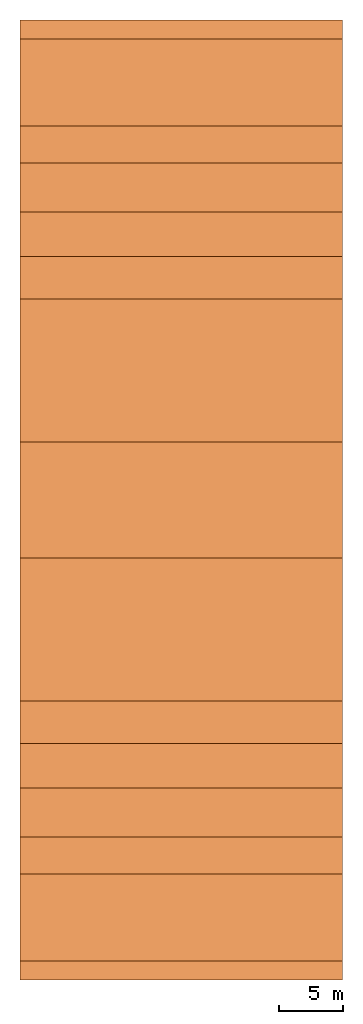
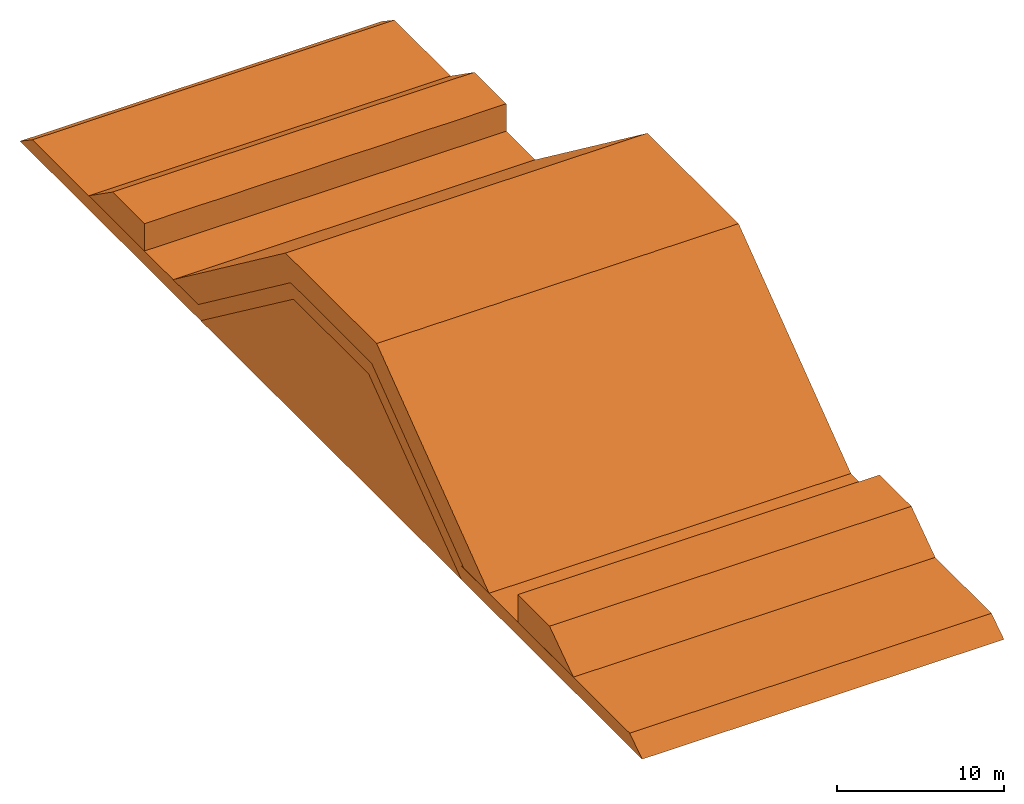
# Not in any storey: 5 civil elements.
"""IFC4 building model written with IfcOpenShell, lengths in metres."""

import ifcopenshell
import ifcopenshell.guid

model = None  # the IFC model being written
_history = None  # IfcOwnerHistory: only IFC2X3 demands one
_inside = {}  # id of a spatial element -> (the spatial element, [elements in it])
_under = {}  # id of a project, library or spatial element -> (it, [spatial elements below it])
_declared = {}  # id of a project -> (the project, [libraries it declares])
_typed = {}  # id of a type object -> (the type object, [elements of that type])
_made_of = {}  # id of a material, layer set ... -> (it, [elements and type objects made of it])


def new_model(schema):
    """Start an empty IFC model of exactly this schema.

    Asked for "IFC4X3", IfcOpenShell would pick the latest addendum, in which some entities
    have other attributes; the version numbers below select the first issue.
    IFC2X3 requires an IfcOwnerHistory on every rooted entity: one is made here for all.
    """
    global model, _history
    if schema == "IFC4X3":
        model = ifcopenshell.file(schema_version=(4, 3, 0, 0))
    else:
        model = ifcopenshell.file(schema=schema)
    _inside.clear()
    _under.clear()
    _declared.clear()
    _typed.clear()
    _made_of.clear()
    _history = None
    if model.schema == "IFC2X3":
        org = make("IfcOrganization", Name="unknown")
        user = make(
            "IfcPersonAndOrganization",
            ThePerson=make("IfcPerson", FamilyName="unknown"),
            TheOrganization=org,
        )
        app = make(
            "IfcApplication",
            ApplicationDeveloper=org,
            Version="unknown",
            ApplicationFullName="unknown",
            ApplicationIdentifier="unknown",
        )
        _history = make(
            "IfcOwnerHistory",
            OwningUser=user,
            OwningApplication=app,
            ChangeAction="ADDED",
            CreationDate=0,
        )
    return model


def make(cls, **values):
    """One entity of the class cls with the attributes given. An attribute that is None is left unset."""
    return model.create_entity(
        cls, **{name: value for name, value in values.items() if value is not None}
    )


def entity(cls, *values):
    """Any entity or typed value of the class cls, its attributes in the order of the schema. None: left unset."""
    e = model.create_entity(cls)
    for i, value in enumerate(values):
        if value is not None:
            e[i] = value
    return e


def rooted(cls, **values):
    """An entity with a GlobalId (a new one), such as an element, a storey or a relation."""
    return make(cls, GlobalId=ifcopenshell.guid.new(), OwnerHistory=_history, **values)


def si_unit(unit_type, name, prefix=None):
    """IfcSIUnit, for example si_unit("LENGTHUNIT", "METRE", prefix="MILLI")."""
    return make("IfcSIUnit", UnitType=unit_type, Prefix=prefix, Name=name)


def converted_unit(unit_type, name, factor, base, dimensions=None, offset=None):
    """IfcConversionBasedUnit, such as the inch: factor (a typed value) times the base unit."""
    return make(
        "IfcConversionBasedUnit"
        if offset is None
        else "IfcConversionBasedUnitWithOffset",
        ConversionOffset=offset,
        Dimensions=None
        if dimensions is None
        else entity("IfcDimensionalExponents", *dimensions),
        UnitType=unit_type,
        Name=name,
        ConversionFactor=make(
            "IfcMeasureWithUnit", ValueComponent=factor, UnitComponent=base
        ),
    )


def assignment(units):
    """IfcUnitAssignment: the units of a project."""
    return None if units is None else make("IfcUnitAssignment", Units=units)


def point(xyz):
    """IfcCartesianPoint."""
    return None if xyz is None else make("IfcCartesianPoint", Coordinates=xyz)


def direction(xyz):
    """IfcDirection."""
    return None if xyz is None else make("IfcDirection", DirectionRatios=xyz)


def frame(location, z_axis=None, x_axis=None):
    """IfcAxis2Placement3D, a coordinate frame: its origin and axes. An axis left out is left unset."""
    return make(
        "IfcAxis2Placement3D",
        Location=point(location),
        Axis=direction(z_axis),
        RefDirection=direction(x_axis),
    )


def frame_2d(location, x_axis=None):
    """IfcAxis2Placement2D, a coordinate frame in the plane: its origin and x axis."""
    return make(
        "IfcAxis2Placement2D", Location=point(location), RefDirection=direction(x_axis)
    )


def origin_with_axes():
    """The frame at (0, 0, 0) with the z axis (0, 0, 1) and the x axis (1, 0, 0) written out."""
    return frame((0.0, 0.0, 0.0), z_axis=(0.0, 0.0, 1.0), x_axis=(1.0, 0.0, 0.0))


def origin_2d_with_axis():
    """The frame at (0, 0) in the plane with the x axis (1, 0) written out."""
    return frame_2d((0.0, 0.0), x_axis=(1.0, 0.0))


def place(relative_to, where):
    """IfcLocalPlacement: puts the frame where relative to a parent placement (None: the world)."""
    return make(
        "IfcLocalPlacement", PlacementRelTo=relative_to, RelativePlacement=where
    )


def context(
    kind, dimensions, precision=None, world=None, true_north=None, identifier=None
):
    """IfcGeometricRepresentationContext, for example the 3D "Model" context."""
    return make(
        "IfcGeometricRepresentationContext",
        ContextIdentifier=identifier,
        ContextType=kind,
        CoordinateSpaceDimension=dimensions,
        Precision=precision,
        WorldCoordinateSystem=world,
        TrueNorth=true_north,
    )


def subcontext(parent, identifier, kind, view, scale=None):
    """IfcGeometricRepresentationSubContext, for example "Body" below "Model"."""
    return make(
        "IfcGeometricRepresentationSubContext",
        ContextIdentifier=identifier,
        ContextType=kind,
        ParentContext=parent,
        TargetScale=scale,
        TargetView=view,
    )


def project(units=None, contexts=None):
    """IfcProject with its units and contexts."""
    return rooted(
        "IfcProject",
        Name="project",
        RepresentationContexts=contexts,
        UnitsInContext=assignment(units),
    )


def spatial(cls, under=None, at=None, **own):
    """A site, building, storey or space (cls), placed at a placement, below another one or the project."""
    s = rooted(cls, ObjectPlacement=at, **own)
    if under is not None:
        _under.setdefault(under.id(), (under, []))[1].append(s)
    return s


def point_list(points):
    """IfcCartesianPointList2D or 3D."""
    cls = (
        "IfcCartesianPointList2D" if len(points[0]) == 2 else "IfcCartesianPointList3D"
    )
    return make(cls, CoordList=points)


def polygons(points, faces, closed=None, point_numbers=None):
    """IfcPolygonalFaceSet: a face is its outer loop, then its inner loops; points numbered from 1."""
    made = []
    for loops in faces:
        if len(loops) == 1:
            made.append(make("IfcIndexedPolygonalFace", CoordIndex=loops[0]))
        else:
            made.append(
                make(
                    "IfcIndexedPolygonalFaceWithVoids",
                    CoordIndex=loops[0],
                    InnerCoordIndices=loops[1:],
                )
            )
    return make(
        "IfcPolygonalFaceSet",
        Coordinates=point_list(points),
        Closed=closed,
        Faces=made,
        PnIndex=point_numbers,
    )


def shape(context_of_items, identifier, shape_type, items):
    """IfcShapeRepresentation: the items that make up one representation, for example the "Body"."""
    return make(
        "IfcShapeRepresentation",
        ContextOfItems=context_of_items,
        RepresentationIdentifier=identifier,
        RepresentationType=shape_type,
        Items=items,
    )


def made_of(thing, what):
    """Note that an element or type object is made of a material, layer set ...; save() writes the relation."""
    if what is not None:
        _made_of.setdefault(what.id(), (what, []))[1].append(thing)
    return thing


def element(
    cls,
    number,
    at=None,
    inside=None,
    cuts=None,
    type_object=None,
    material=None,
    context=None,
    identifier="Body",
    shape_type=None,
    held_by="IfcProductDefinitionShape",
    body=None,
    shapes=None,
    **own,
):
    """One element of the class cls, such as IfcWall. Its Tag is "e" and its number.

    at: its placement. inside: the storey or other place that contains it. cuts: it is an
    opening in that element (IfcRelVoidsElement). A single representation is given by context,
    identifier, shape_type and body (its items); several are given by shapes. held_by: the class
    of the entity that holds the representations. save() writes the other relations.
    """
    e = rooted(cls, Tag="e%d" % number, ObjectPlacement=at, **own)
    if body is not None:
        shapes = [shape(context, identifier, shape_type, body)]
    if shapes is not None:
        e.Representation = make(held_by, Representations=shapes)
    if inside is not None:
        _inside.setdefault(inside.id(), (inside, []))[1].append(e)
    if cuts is not None:
        rooted(
            "IfcRelVoidsElement", RelatingBuildingElement=cuts, RelatedOpeningElement=e
        )
    if type_object is not None:
        _typed.setdefault(type_object.id(), (type_object, []))[1].append(e)
    return made_of(e, material)


def aggregate(whole, parts):
    """IfcRelAggregates: a whole, such as a stair, and the parts it consists of."""
    return rooted("IfcRelAggregates", RelatingObject=whole, RelatedObjects=parts)


def save(model, path):
    """Write the relations noted so far, then the file.

    IfcRelAggregates (storeys below a building ...), IfcRelContainedInSpatialStructure (elements
    in a storey), IfcRelDefinesByType, IfcRelAssociatesMaterial and IfcRelDeclares: one each for
    every whole, place, type object, material and project.
    """
    for whole, parts in _under.values():
        aggregate(whole, parts)
    for where, things in _inside.values():
        rooted(
            "IfcRelContainedInSpatialStructure",
            RelatedElements=things,
            RelatingStructure=where,
        )
    for kind, things in _typed.values():
        rooted("IfcRelDefinesByType", RelatedObjects=things, RelatingType=kind)
    for what, things in _made_of.values():
        rooted("IfcRelAssociatesMaterial", RelatedObjects=things, RelatingMaterial=what)
    for by, libraries in _declared.values():
        rooted("IfcRelDeclares", RelatingContext=by, RelatedDefinitions=libraries)
    model.write(path)


model = new_model("IFC4")

# Units and contexts
model_context = context("Model", 3, precision=1e-05, world=origin_with_axes())
plan_context = context("Plan", 2, precision=1e-05, world=origin_2d_with_axis())
body_context = subcontext(model_context, "Body", "Model", "MODEL_VIEW")
ifc_project = project(units=[si_unit("VOLUMEUNIT", "CUBIC_METRE"), si_unit("LENGTHUNIT", "METRE"), converted_unit("PLANEANGLEUNIT", "degree", entity("IfcReal", 0.0174532925199433), si_unit("PLANEANGLEUNIT", "RADIAN"), dimensions=[0, 0, 0, 0, 0, 0, 0]), si_unit("AREAUNIT", "SQUARE_METRE")], contexts=[model_context, plan_context])

# Site, building
site_placement = place(None, origin_with_axes())
site = spatial("IfcSite", under=ifc_project, at=site_placement)
building_placement = place(site_placement, origin_with_axes())
building = spatial("IfcBuilding", under=site, at=building_placement, Name="Building")

# Civil elements
civil_element_1_placement = place(building_placement, origin_with_axes())
element("IfcCivilElement", 1, at=civil_element_1_placement, inside=building, Name="Core", ObjectType="IfcCivilElementType", context=body_context, shape_type="Tessellation", body=[
    polygons([(0.0, -15.6000003814697, 0.0), (0.0, 15.6000003814697, 0.0), (25.0, -15.6000003814697, 0.0), (25.0, 15.6000003814697, 0.0), (0.0, -4.5, 8.30000019073486), (0.0, 4.5, 8.30000019073486), (25.0, -4.5, 8.30000019073486), (25.0, 4.5, 8.30000019073486), (0.00543623324483633, -15.607964515686, -0.00264844717457891), (0.00210548774339259, 15.5969152450562, -0.00927639659494162), (25.0054359436035, -15.607964515686, -0.00264844717457891), (25.0021057128906, 15.5969152450562, -0.00927639659494162), (0.00929563399404287, -4.50349807739258, 8.29883670806885), (0.00642501097172499, 4.49758195877075, 8.29272842407227), (25.0092964172363, -4.50349807739258, 8.29883670806885), (25.0064258575439, 4.49758195877075, 8.29272842407227)], [[[1, 3, 4, 2]], [[5, 7, 8, 6]], [[2, 6, 8, 4]], [[1, 5, 7, 3]], [[3, 7, 8, 4]], [[1, 5, 6, 2]], [[9, 10, 12, 11]], [[13, 14, 16, 15]], [[12, 14, 10]], [[9, 11, 15, 13]], [[11, 16, 15]], [[9, 14, 13]], [[12, 16, 14]], [[11, 12, 16]], [[9, 10, 14]]], closed=True),
])
civil_element_2_placement = place(building_placement, origin_with_axes())
element("IfcCivilElement", 2, at=civil_element_2_placement, inside=building, Name="UnderLayer", ObjectType="IfcCivilElementType", context=body_context, shape_type="Tessellation", body=[
    polygons([(0.0, -17.25, 0.0), (0.0, 17.25, 0.0), (25.0, -17.25, 0.0), (25.0, 17.25, 0.0), (0.0, -4.84999990463257, 9.30000019073486), (0.0, 4.84999990463257, 9.30000019073486), (25.0, -4.84999990463257, 9.30000019073486), (25.0, 4.84999990463257, 9.30000019073486), (25.0, -4.5, 8.30000019073486), (25.0, -15.6000003814697, 0.0), (25.0, 4.5, 8.30000019073486), (25.0, 15.6000003814697, 0.0), (0.0, -4.5, 8.30000019073486), (0.0, -15.6000003814697, 0.0), (0.0, 4.5, 8.30000019073486), (0.0, 15.6000003814697, 0.0), (0.0, -15.5799999237061, 0.0), (0.0, -37.2299995422363, 0.0), (25.0, -15.5799999237061, 0.0), (25.0, -37.2299995422363, 0.0), (0.0, -15.5799999237061, 1.0), (0.0, -35.7400016784668, 1.0), (25.0, -15.5799999237061, 1.0), (25.0, -35.7400016784668, 1.0), (0.0, 15.5799999237061, 0.0), (0.0, 37.2299995422363, 0.0), (25.0, 15.5799999237061, 0.0), (25.0, 37.2299995422363, 0.0), (0.0, 15.5799999237061, 1.0), (0.0, 35.7400016784668, 1.0), (25.0, 15.5799999237061, 1.0), (25.0, 35.7400016784668, 1.0), (0.00543653080239892, -17.257963180542, -0.00265413033775985), (0.00211049360223114, 17.2469081878662, -0.00927314534783363), (25.0054359436035, -17.257963180542, -0.00265413033775985), (25.0021114349365, 17.2469081878662, -0.00927314534783363), (0.00929215922951698, -4.85350561141968, 9.29883193969727), (0.00642373831942677, 4.84757614135742, 9.29272937774658), (25.0092926025391, -4.85350561141968, 9.29883193969727), (25.0064239501953, 4.84757614135742, 9.29272937774658), (25.0092964172363, -4.49650192260742, 8.30116367340088), (25.0064258575439, -15.5975828170776, -0.00727136200293899), (25.0064258575439, 4.50241804122925, 8.30727195739746), (25.0092964172363, 15.6034984588623, -0.00116328825242817), (0.00929563399404287, -4.49650192260742, 8.30116367340088), (0.00642501097172499, -15.5975828170776, -0.00727136200293899), (0.00642501097172499, 4.50241804122925, 8.30727195739746), (0.00929563399404287, 15.6034984588623, -0.00116328825242817), (-0.00577350286766887, -15.5857734680176, 0.00577350286766887), (-0.00192981504369527, -37.2328567504883, 0.00938660278916359), (24.9942264556885, -15.5857734680176, 0.00577350286766887), (24.9980697631836, -37.2328567504883, 0.00938660278916359), (-0.00577350286766887, -15.5857734680176, 1.00577354431152), (-0.00647047720849514, -35.7422218322754, 1.00729393959045), (24.9942264556885, -15.5857734680176, 1.00577354431152), (24.9935302734375, -35.7422218322754, 1.00729393959045), (0.00577350286766887, 15.5742263793945, -0.00577350286766887), (0.00192981504369527, 37.2271423339844, -0.00938660278916359), (25.0057735443115, 15.5742263793945, -0.00577350286766887), (25.0019302368164, 37.2271423339844, -0.00938660278916359), (0.00577350286766887, 15.5742263793945, 0.994226515293121), (0.00647047720849514, 35.7377815246582, 0.992706060409546), (25.0057735443115, 15.5742263793945, 0.994226515293121), (25.0064697265625, 35.7377815246582, 0.992706060409546)], [[[12, 4, 2, 16]], [[14, 1, 3, 10]], [[5, 7, 8, 6]], [[2, 6, 8, 4]], [[1, 5, 7, 3]], [[3, 7, 8, 4, 12, 11, 9, 10]], [[1, 5, 6, 2, 16, 15, 13, 14]], [[15, 11, 9, 13]], [[11, 15, 16, 12]], [[10, 9, 13, 14]], [[17, 19, 20, 18]], [[21, 23, 24, 22]], [[18, 22, 24, 20]], [[17, 21, 23, 19]], [[19, 23, 24, 20]], [[17, 21, 22, 18]], [[25, 27, 28, 26]], [[29, 31, 32, 30]], [[26, 30, 32, 28]], [[25, 29, 31, 27]], [[27, 31, 32, 28]], [[25, 29, 30, 26]], [[44, 48, 34, 36]], [[46, 42, 35, 33]], [[37, 38, 40, 39]], [[34, 36, 40, 38]], [[35, 37, 33]], [[43, 44, 40]], [[47, 48, 38]], [[47, 45, 41, 43]], [[43, 44, 48, 47]], [[42, 46, 45, 41]], [[49, 50, 52, 51]], [[53, 54, 56, 55]], [[50, 56, 54]], [[49, 51, 55, 53]], [[51, 56, 55]], [[49, 54, 53]], [[57, 58, 60, 59]], [[61, 62, 64, 63]], [[58, 60, 64, 62]], [[57, 59, 63, 61]], [[59, 64, 63]], [[57, 62, 61]], [[35, 39, 37]], [[39, 35, 42]], [[39, 42, 41]], [[44, 36, 40]], [[39, 41, 40]], [[41, 43, 40]], [[37, 33, 46]], [[37, 46, 45]], [[48, 34, 38]], [[37, 45, 38]], [[45, 47, 38]], [[50, 52, 56]], [[51, 52, 56]], [[49, 50, 54]], [[59, 60, 64]], [[57, 58, 62]]], closed=True),
])
civil_element_3_placement = place(building_placement, origin_with_axes())
element("IfcCivilElement", 3, at=civil_element_3_placement, inside=building, Name="FilterLayer", ObjectType="IfcCivilElementType", context=body_context, shape_type="Tessellation", body=[
    polygons([(0.0, -5.44999980926514, 9.30000019073486), (0.0, 5.44999980926514, 9.30000019073486), (25.0, -5.44999980926514, 9.30000019073486), (25.0, 5.44999980926514, 9.30000019073486), (0.0, -5.44999980926514, 11.1000003814697), (0.0, 5.44999980926514, 11.1000003814697), (25.0, -5.44999980926514, 11.1000003814697), (25.0, 5.44999980926514, 11.1000003814697), (0.0, -18.8999996185303, 1.0), (0.0, -15.8999996185303, 1.0), (25.0, -18.8999996185303, 1.0), (25.0, -15.8999996185303, 1.0), (0.0, -5.44999980926514, 11.1000003814697), (0.0, -2.45000004768372, 11.1000003814697), (25.0, -5.44999980926514, 11.1000003814697), (25.0, -2.45000004768372, 11.1000003814697), (0.0, 18.8999996185303, 1.0), (0.0, 15.8999996185303, 1.0), (25.0, 18.8999996185303, 1.0), (25.0, 15.8999996185303, 1.0), (0.0, 5.44999980926514, 11.1000003814697), (0.0, 2.45000004768372, 11.1000003814697), (25.0, 5.44999980926514, 11.1000003814697), (25.0, 2.45000004768372, 11.1000003814697), (0.00577350286766887, -5.45577335357666, 9.29422664642334), (0.00577350286766887, 5.44422626495361, 9.29422664642334), (25.0057735443115, -5.45577335357666, 9.29422664642334), (25.0057735443115, 5.44422626495361, 9.29422664642334), (0.00577350286766887, -5.45577335357666, 11.0942268371582), (0.00577350286766887, 5.44422626495361, 11.0942268371582), (25.0057735443115, -5.45577335357666, 11.0942268371582), (25.0057735443115, 5.44422626495361, 11.0942268371582), (0.00543665327131748, -18.9079608917236, 0.99734354019165), (0.0092907240614295, -15.9035081863403, 0.998829245567322), (25.0054359436035, -18.9079608917236, 0.99734354019165), (25.0092906951904, -15.9035081863403, 0.998829245567322), (0.0092907240614295, -5.45350885391235, 11.0988292694092), (0.00543665327131748, -2.45796155929565, 11.0973434448242), (25.0092906951904, -5.45350885391235, 11.0988292694092), (25.0054359436035, -2.45796155929565, 11.0973434448242), (-0.00543665327131748, 18.8920383453369, 1.00265645980835), (-0.0092907240614295, 15.8964910507202, 1.00117075443268), (24.9945640563965, 18.8920383453369, 1.00265645980835), (24.9907093048096, 15.8964910507202, 1.00117075443268), (-0.0092907240614295, 5.44649076461792, 11.1011714935303), (-0.00543665327131748, 2.44203853607178, 11.1026573181152), (24.9907093048096, 5.44649076461792, 11.1011714935303), (24.9945640563965, 2.44203853607178, 11.1026573181152)], [[[1, 3, 4, 2]], [[5, 7, 8, 6]], [[2, 6, 8, 4]], [[1, 5, 7, 3]], [[3, 7, 8, 4]], [[1, 5, 6, 2]], [[9, 11, 12, 10]], [[13, 15, 16, 14]], [[14, 12, 10]], [[9, 13, 15, 11]], [[15, 12, 11]], [[9, 13, 14, 10]], [[17, 19, 20, 18]], [[21, 23, 24, 22]], [[22, 20, 18]], [[17, 21, 23, 19]], [[23, 20, 19]], [[17, 21, 22, 18]], [[25, 26, 28, 27]], [[29, 30, 32, 31]], [[26, 28, 32, 30]], [[25, 27, 31, 29]], [[27, 28, 32, 31]], [[25, 26, 30, 29]], [[33, 34, 36, 35]], [[37, 38, 40, 39]], [[34, 36, 40, 38]], [[33, 35, 39, 37]], [[36, 39, 35]], [[34, 37, 33]], [[41, 42, 44, 43]], [[45, 46, 48, 47]], [[42, 44, 48, 46]], [[41, 43, 47, 45]], [[44, 47, 43]], [[42, 45, 41]], [[14, 16, 12]], [[15, 16, 12]], [[22, 24, 20]], [[23, 24, 20]], [[36, 40, 39]], [[34, 38, 37]], [[44, 48, 47]], [[42, 46, 45]]], closed=True),
])
civil_element_4_placement = place(building_placement, origin_with_axes())
element("IfcCivilElement", 4, at=civil_element_4_placement, inside=building, ObjectType="IfcCivilElementType", context=body_context, shape_type="Tessellation", body=[
    polygons([(0.0, 22.3500003814697, 1.0), (0.0, 29.0, 1.0), (25.0, 22.3500003814697, 1.0), (25.0, 29.0, 1.0), (0.0, 22.3500003814697, 3.0), (0.0, 26.1499996185303, 3.0), (25.0, 22.3500003814697, 3.0), (25.0, 26.1499996185303, 3.0), (0.00577350286766887, 22.3442268371582, 0.994226515293121), (0.00200127973221242, 28.997049331665, 0.990657329559326), (25.0057735443115, 22.3442268371582, 0.994226515293121), (25.0020008087158, 28.997049331665, 0.990657329559326), (0.00577350286766887, 22.3442268371582, 2.99422645568848), (0.00645179022103548, 26.1476974487305, 2.99271440505981), (25.0057735443115, 22.3442268371582, 2.99422645568848), (25.0064525604248, 26.1476974487305, 2.99271440505981)], [[[1, 3, 4, 2]], [[5, 7, 8, 6]], [[6, 4, 2]], [[1, 5, 7, 3]], [[3, 7, 8, 4]], [[1, 5, 6, 2]], [[9, 10, 12, 11]], [[13, 14, 16, 15]], [[10, 12, 16, 14]], [[9, 11, 15, 13]], [[11, 16, 15]], [[9, 14, 13]], [[6, 8, 4]], [[11, 12, 16]], [[9, 10, 14]]], closed=True),
])
civil_element_5_placement = place(building_placement, origin_with_axes())
element("IfcCivilElement", 5, at=civil_element_5_placement, inside=building, ObjectType="IfcCivilElementType", context=body_context, shape_type="Tessellation", body=[
    polygons([(0.0, -22.3500003814697, 1.0), (0.0, -29.0, 1.0), (25.0, -22.3500003814697, 1.0), (25.0, -29.0, 1.0), (0.0, -22.3500003814697, 3.0), (0.0, -26.1499996185303, 3.0), (25.0, -22.3500003814697, 3.0), (25.0, -26.1499996185303, 3.0), (-0.00577350286766887, -22.3557739257812, 1.00577354431152), (-0.00200127973221242, -29.002950668335, 1.00934267044067), (24.9942264556885, -22.3557739257812, 1.00577354431152), (24.9979991912842, -29.002950668335, 1.00934267044067), (-0.00577350286766887, -22.3557739257812, 3.00577354431152), (-0.00645179022103548, -26.1523017883301, 3.00728559494019), (24.9942264556885, -22.3557739257812, 3.00577354431152), (24.9935474395752, -26.1523017883301, 3.00728559494019)], [[[1, 3, 4, 2]], [[5, 7, 8, 6]], [[6, 4, 2]], [[1, 5, 7, 3]], [[3, 7, 8, 4]], [[1, 5, 6, 2]], [[9, 10, 12, 11]], [[13, 14, 16, 15]], [[10, 12, 16, 14]], [[9, 11, 15, 13]], [[11, 16, 15]], [[9, 14, 13]], [[6, 8, 4]], [[11, 12, 16]], [[9, 10, 14]]], closed=True),
])

save(model, "model.ifc")
